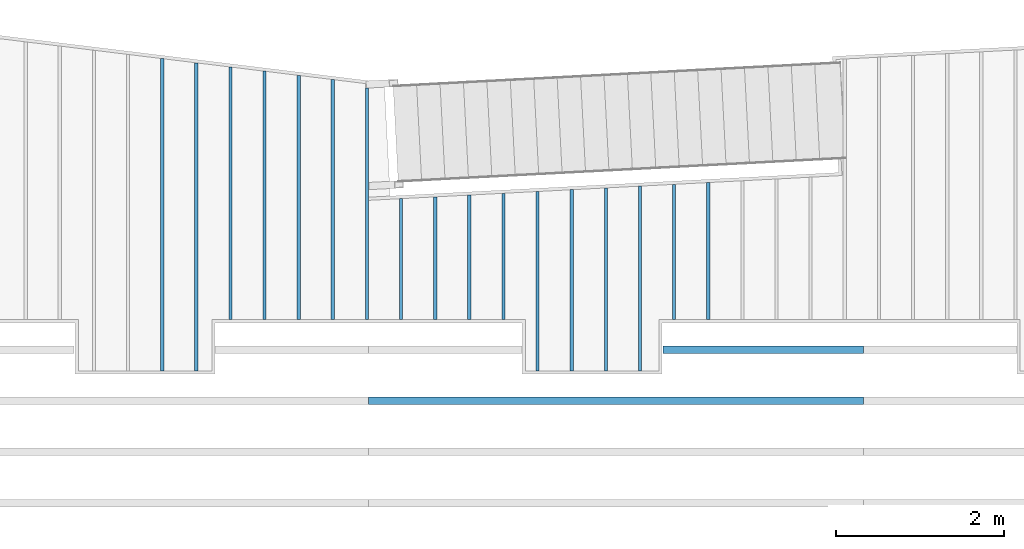
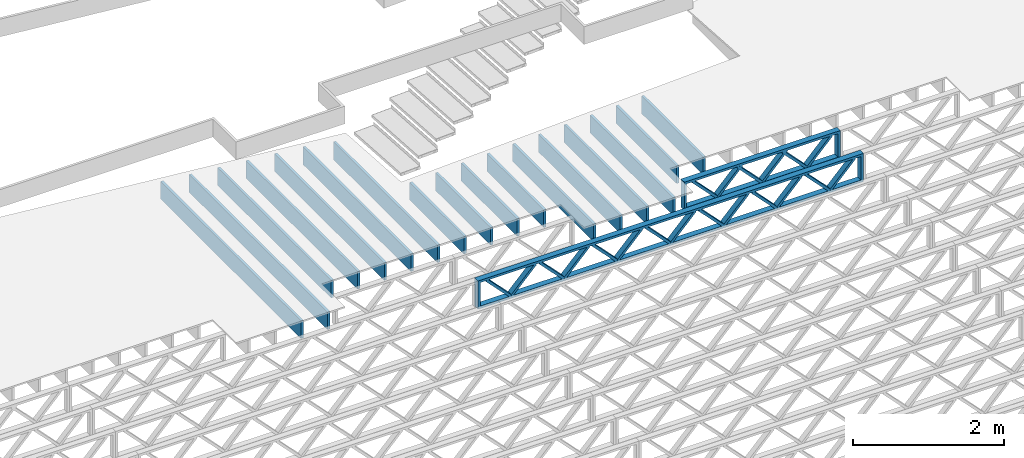
# One storey, part 10 of 23: 19 beams, 2 elements without a shape of their own.
"""IFC4 building model written with IfcOpenShell, lengths in feet."""

from ifc_helpers import new_model, entity, si_unit, converted_unit, derived_unit, direction, frame, frame_2d, origin, origin_2d_with_axis, place, context, subcontext, project, spatial, rectangle, extrude, source, transform, mapped, material, material_profile, profile_set, profile_usage, type_object, type_shapes, element, aggregate, save


model = new_model("IFC4")

# Units and contexts
model_context_1 = context("Model", 3, precision=0.0001, world=origin(), true_north=direction((6.12303176911189e-17, 1.0)))
model_context_2 = context("Model", 3, precision=0.0001, world=origin(), true_north=direction((6.12303176911189e-17, 1.0)))
body_context = subcontext(model_context_2, "Body", "Model", "MODEL_VIEW")
ifc_project = project(units=[converted_unit("LENGTHUNIT", "FOOT", entity("IfcRatioMeasure", 0.3048), si_unit("LENGTHUNIT", "METRE"), dimensions=[1, 0, 0, 0, 0, 0, 0]), converted_unit("AREAUNIT", "SQUARE FOOT", entity("IfcRatioMeasure", 0.09290304), si_unit("AREAUNIT", "SQUARE_METRE"), dimensions=[2, 0, 0, 0, 0, 0, 0]), converted_unit("VOLUMEUNIT", "CUBIC FOOT", entity("IfcRatioMeasure", 0.028316846592), si_unit("VOLUMEUNIT", "CUBIC_METRE"), dimensions=[3, 0, 0, 0, 0, 0, 0]), converted_unit("PLANEANGLEUNIT", "DEGREE", entity("IfcRatioMeasure", 0.0174532925199433), si_unit("PLANEANGLEUNIT", "RADIAN"), dimensions=[0, 0, 0, 0, 0, 0, 0]), si_unit("MASSUNIT", "GRAM", prefix="KILO"), derived_unit("MASSDENSITYUNIT", [(si_unit("MASSUNIT", "GRAM", prefix="KILO"), 1), (si_unit("LENGTHUNIT", "METRE"), -3)]), derived_unit("MOMENTOFINERTIAUNIT", [(si_unit("LENGTHUNIT", "METRE"), 4)]), si_unit("TIMEUNIT", "SECOND"), si_unit("FREQUENCYUNIT", "HERTZ"), si_unit("THERMODYNAMICTEMPERATUREUNIT", "DEGREE_CELSIUS"), derived_unit("THERMALTRANSMITTANCEUNIT", [(si_unit("MASSUNIT", "GRAM", prefix="KILO"), 1), (si_unit("THERMODYNAMICTEMPERATUREUNIT", "KELVIN"), -1), (si_unit("TIMEUNIT", "SECOND"), -3)]), derived_unit("VOLUMETRICFLOWRATEUNIT", [(si_unit("LENGTHUNIT", "METRE"), 3), (si_unit("TIMEUNIT", "SECOND"), -1)]), si_unit("ELECTRICCURRENTUNIT", "AMPERE"), si_unit("ELECTRICVOLTAGEUNIT", "VOLT"), si_unit("POWERUNIT", "WATT"), si_unit("FORCEUNIT", "NEWTON"), si_unit("ILLUMINANCEUNIT", "LUX"), si_unit("LUMINOUSFLUXUNIT", "LUMEN"), si_unit("LUMINOUSINTENSITYUNIT", "CANDELA"), derived_unit("USERDEFINED", [(si_unit("MASSUNIT", "GRAM", prefix="KILO"), -1), (si_unit("LENGTHUNIT", "METRE"), -2), (si_unit("TIMEUNIT", "SECOND"), 3), (si_unit("LUMINOUSFLUXUNIT", "LUMEN"), 1)]), derived_unit("LINEARVELOCITYUNIT", [(si_unit("LENGTHUNIT", "METRE"), 1), (si_unit("TIMEUNIT", "SECOND"), -1)]), si_unit("PRESSUREUNIT", "PASCAL"), derived_unit("USERDEFINED", [(si_unit("LENGTHUNIT", "METRE"), -2), (si_unit("MASSUNIT", "GRAM", prefix="KILO"), 1), (si_unit("TIMEUNIT", "SECOND"), -2)]), derived_unit("LINEARFORCEUNIT", [(si_unit("MASSUNIT", "GRAM", prefix="KILO"), 1), (si_unit("LENGTHUNIT", "METRE"), 1), (si_unit("TIMEUNIT", "SECOND"), -2), (si_unit("LENGTHUNIT", "METRE"), -1)]), derived_unit("PLANARFORCEUNIT", [(si_unit("MASSUNIT", "GRAM", prefix="KILO"), 1), (si_unit("LENGTHUNIT", "METRE"), 1), (si_unit("TIMEUNIT", "SECOND"), -2), (si_unit("LENGTHUNIT", "METRE"), -2)])], contexts=[model_context_1])

# Site, building, storey
site_placement = place(None, origin())
site = spatial("IfcSite", under=ifc_project, at=site_placement, CompositionType="ELEMENT")
building_placement = place(site_placement, origin())
building = spatial("IfcBuilding", under=site, at=building_placement, CompositionType="ELEMENT")
storey_placement = place(building_placement, frame((0.0, 0.0, 10.8020833333333)))
storey = spatial("IfcBuildingStorey", under=building, at=storey_placement, Name="2ND FLOOR", CompositionType="ELEMENT", Elevation=10.8020833333333)

# Assembly, beams
assembly_1_placement = place(storey_placement, origin())
assembly_1 = element("IfcElementAssembly", 1, at=assembly_1_placement, inside=storey, Name="Structural Beam System:Structural Framing System", ObjectType="Structural Beam System:Structural Framing System", AssemblyPlace="NOTDEFINED", PredefinedType="BEAM_GRID")
ifc_material_1 = material(Category="Materials")
ifc_material_profile_1 = material_profile(ifc_material_1, rectangle(XDim=0.9375, YDim=0.125000000000011, at=origin_2d_with_axis()))
ifc_profile_set_1 = profile_set([ifc_material_profile_1])
ifc_profile_usage_1 = profile_usage(ifc_profile_set_1, cardinal=8)
beam_type_1 = type_object("IfcBeamType", PredefinedType="BEAM", material=ifc_profile_set_1)
shared_shape_1 = source(origin(), body_context, "Body", "SweptSolid", [
    extrude(rectangle(XDim=0.9375, YDim=0.125000000000011, at=origin_2d_with_axis()), frame((-2.6429404122805, 0.0, 0.0), z_axis=(1.0, 0.0, 0.0), x_axis=(0.0, 0.0, -1.0)), (0.0, 0.0, 1.0), 5.28588082456099),
])
type_shapes(beam_type_1, [shared_shape_1])
beam_1_placement = place(assembly_1_placement, frame((-171.800660485462, 961.671541385545, -0.729166666666744), z_axis=(0.0, 0.0, 1.0), x_axis=(0.0, 1.0, 0.0)))
beam_1 = element("IfcBeam", 2, at=beam_1_placement, type_object=beam_type_1, material=ifc_profile_usage_1, PredefinedType="BEAM", context=body_context, shape_type="MappedRepresentation", body=[
    mapped(shared_shape_1, transform((0.0, 0.0, 0.0), scale=1.0)),
])
ifc_profile_usage_2 = profile_usage(ifc_profile_set_1, cardinal=8)
beam_type_2 = type_object("IfcBeamType", PredefinedType="BEAM", material=ifc_profile_set_1)
shared_shape_2 = source(origin(), body_context, "Body", "SweptSolid", [
    extrude(rectangle(XDim=0.9375, YDim=0.125000000000011, at=origin_2d_with_axis()), frame((-3.60800160473184, 0.0, 0.0), z_axis=(1.0, 0.0, 0.0), x_axis=(0.0, 0.0, -1.0)), (0.0, 0.0, 1.0), 7.21600320946368),
])
type_shapes(beam_type_2, [shared_shape_2])
beam_2_placement = place(assembly_1_placement, frame((-173.133993818795, 960.63660315405, -0.729166666666744), z_axis=(0.0, 0.0, 1.0), x_axis=(0.0, 1.0, 0.0)))
beam_2 = element("IfcBeam", 3, at=beam_2_placement, type_object=beam_type_2, material=ifc_profile_usage_2, PredefinedType="BEAM", context=body_context, shape_type="MappedRepresentation", body=[
    mapped(shared_shape_2, transform((0.0, 0.0, 0.0), scale=1.0)),
])
ifc_profile_usage_3 = profile_usage(ifc_profile_set_1, cardinal=8)
beam_type_3 = type_object("IfcBeamType", PredefinedType="BEAM", material=ifc_profile_set_1)
shared_shape_3 = source(origin(), body_context, "Body", "SweptSolid", [
    extrude(rectangle(XDim=0.9375, YDim=0.125000000000011, at=origin_2d_with_axis()), frame((-3.53812456568801, 0.0, 0.0), z_axis=(1.0, 0.0, 0.0), x_axis=(0.0, 0.0, -1.0)), (0.0, 0.0, 1.0), 7.07624913137602),
])
type_shapes(beam_type_3, [shared_shape_3])
beam_3_placement = place(assembly_1_placement, frame((-175.800660485462, 960.566726115006, -0.729166666666744), z_axis=(0.0, 0.0, 1.0), x_axis=(0.0, 1.0, 0.0)))
beam_3 = element("IfcBeam", 4, at=beam_3_placement, type_object=beam_type_3, material=ifc_profile_usage_3, PredefinedType="BEAM", context=body_context, shape_type="MappedRepresentation", body=[
    mapped(shared_shape_3, transform((0.0, 0.0, 0.0), scale=1.0)),
])
ifc_profile_usage_4 = profile_usage(ifc_profile_set_1, cardinal=8)
beam_type_4 = type_object("IfcBeamType", PredefinedType="BEAM", material=ifc_profile_set_1)
shared_shape_4 = source(origin(), body_context, "Body", "SweptSolid", [
    extrude(rectangle(XDim=0.9375, YDim=0.125000000000011, at=origin_2d_with_axis()), frame((-4.63214954776987, 0.0, 0.0), z_axis=(1.0, 0.0, 0.0), x_axis=(0.0, 0.0, -1.0)), (0.0, 0.0, 1.0), 9.0453350583723),
])
type_shapes(beam_type_4, [shared_shape_4])
beam_4_placement = place(assembly_1_placement, frame((-183.800660485462, 963.660753064632, -0.729166666666744), z_axis=(0.0, 0.0, 1.0), x_axis=(0.0, 1.0, 0.0)))
beam_4 = element("IfcBeam", 5, at=beam_4_placement, type_object=beam_type_4, material=ifc_profile_usage_4, PredefinedType="BEAM", context=body_context, shape_type="MappedRepresentation", body=[
    mapped(shared_shape_4, transform((0.0, 0.0, 0.0), scale=1.0)),
])
ifc_profile_usage_5 = profile_usage(ifc_profile_set_1, cardinal=8)
beam_type_5 = type_object("IfcBeamType", PredefinedType="BEAM", material=ifc_profile_set_1)
shared_shape_5 = source(origin(), body_context, "Body", "SweptSolid", [
    extrude(rectangle(XDim=0.9375, YDim=0.125000000000011, at=origin_2d_with_axis()), frame((-4.68938955176543, 0.0, 0.0), z_axis=(1.0, 0.0, 0.0), x_axis=(0.0, 0.0, -1.0)), (0.0, 0.0, 1.0), 9.37877910353086),
])
type_shapes(beam_type_5, [shared_shape_5])
beam_5_placement = place(assembly_1_placement, frame((-185.133993818795, 963.717993385622, -0.729166666666744), z_axis=(0.0, 0.0, 1.0), x_axis=(0.0, 1.0, 0.0)))
beam_5 = element("IfcBeam", 6, at=beam_5_placement, type_object=beam_type_5, material=ifc_profile_usage_5, PredefinedType="BEAM", context=body_context, shape_type="MappedRepresentation", body=[
    mapped(shared_shape_5, transform((0.0, 0.0, 0.0), scale=1.0)),
])
ifc_profile_usage_6 = profile_usage(ifc_profile_set_1, cardinal=8)
beam_type_6 = type_object("IfcBeamType", PredefinedType="BEAM", material=ifc_profile_set_1)
shared_shape_6 = source(origin(), body_context, "Body", "SweptSolid", [
    extrude(rectangle(XDim=0.9375, YDim=0.125000000000011, at=origin_2d_with_axis()), frame((-4.77124576720365, 0.0, 0.0), z_axis=(1.0, 0.0, 0.0), x_axis=(0.0, 0.0, -1.0)), (0.0, 0.0, 1.0), 9.5424915344073),
])
type_shapes(beam_type_6, [shared_shape_6])
beam_6_placement = place(assembly_1_placement, frame((-186.467327152129, 963.799849918054, -0.729166666666744), z_axis=(0.0, 0.0, 1.0), x_axis=(0.0, 1.0, 0.0)))
beam_6 = element("IfcBeam", 7, at=beam_6_placement, type_object=beam_type_6, material=ifc_profile_usage_6, PredefinedType="BEAM", context=body_context, shape_type="MappedRepresentation", body=[
    mapped(shared_shape_6, transform((0.0, 0.0, 0.0), scale=1.0)),
])

assembly_2_placement = place(storey_placement, origin())
assembly_2 = element("IfcElementAssembly", 8, at=assembly_2_placement, inside=storey, Name="Structural Beam System:Structural Framing System", ObjectType="Structural Beam System:Structural Framing System", AssemblyPlace="NOTDEFINED", PredefinedType="BEAM_GRID")
ifc_material_2 = material(Name="WOOD TRUSS", Category="Materials")
ifc_material_profile_2 = material_profile(ifc_material_2, rectangle(XDim=1.73473973950632, YDim=0.125, at=frame_2d((-1.11022302462516e-16, 8.32667268468867e-17), x_axis=(1.0, 0.0))))
ifc_material_profile_3 = material_profile(ifc_material_2, rectangle(XDim=1.73473973950633, YDim=0.125, at=frame_2d((-1.11022302462516e-16, 8.32667268468867e-17), x_axis=(1.0, 0.0))))
ifc_material_profile_4 = material_profile(ifc_material_2, rectangle(XDim=1.73473973950632, YDim=0.125, at=frame_2d((-5.55111512312578e-17, 1.38777878078145e-16), x_axis=(1.0, 0.0))))
ifc_material_profile_5 = material_profile(ifc_material_2, rectangle(XDim=1.73473973950633, YDim=0.125, at=frame_2d((-1.11022302462516e-16, 8.32667268468867e-17), x_axis=(1.0, 0.0))))
ifc_material_profile_6 = material_profile(ifc_material_2, rectangle(XDim=1.73473973950632, YDim=0.125, at=frame_2d((-1.11022302462516e-16, 8.32667268468867e-17), x_axis=(1.0, 0.0))))
ifc_material_profile_7 = material_profile(ifc_material_2, rectangle(XDim=1.73473973950633, YDim=0.125, at=frame_2d((-2.77555756156289e-16, 3.05311331771918e-16), x_axis=(1.0, 0.0))))
ifc_material_profile_8 = material_profile(ifc_material_2, rectangle(XDim=1.73473973950632, YDim=0.124999999999999, at=frame_2d((-3.88578058618805e-16, -2.4980018054066e-16), x_axis=(1.0, 0.0))))
ifc_material_profile_9 = material_profile(ifc_material_2, rectangle(XDim=1.73473973950633, YDim=0.125, at=frame_2d((2.77555756156289e-16, -3.05311331771918e-16), x_axis=(1.0, 0.0))))
ifc_material_profile_10 = material_profile(ifc_material_2, rectangle(XDim=1.73473973950632, YDim=0.124999999999999, at=frame_2d((-1.11022302462516e-16, 8.32667268468867e-17), x_axis=(1.0, 0.0))))
ifc_material_profile_11 = material_profile(ifc_material_2, rectangle(XDim=1.73473973950633, YDim=0.125, at=origin_2d_with_axis()))
ifc_material_profile_12 = material_profile(ifc_material_2, rectangle(XDim=0.124999999999982, YDim=0.291666666666668, at=origin_2d_with_axis()))
ifc_material_profile_13 = material_profile(ifc_material_2, rectangle(XDim=0.124999999999932, YDim=0.291666666666664, at=origin_2d_with_axis()))
ifc_material_profile_14 = material_profile(ifc_material_2, rectangle(XDim=1.25000000000002, YDim=0.29166666666667, at=origin_2d_with_axis()))
ifc_material_profile_15 = material_profile(ifc_material_2, rectangle(XDim=1.25000000000004, YDim=0.291666666666667, at=origin_2d_with_axis()))
ifc_profile_set_2 = profile_set([ifc_material_profile_2, ifc_material_profile_3, ifc_material_profile_4, ifc_material_profile_5, ifc_material_profile_6, ifc_material_profile_7, ifc_material_profile_8, ifc_material_profile_9, ifc_material_profile_10, ifc_material_profile_11, ifc_material_profile_12, ifc_material_profile_13, ifc_material_profile_14, ifc_material_profile_15])
ifc_profile_usage_7 = profile_usage(ifc_profile_set_2, cardinal=8)
beam_type_7 = type_object("IfcBeamType", PredefinedType="BEAM", material=ifc_profile_set_2)
shared_shape_7 = source(origin(), body_context, "Body", "SweptSolid", [
    extrude(rectangle(XDim=1.73473973950632, YDim=0.124999999999999, at=frame_2d((5.55111512312578e-16, 7.21644966006352e-16), x_axis=(1.0, 0.0))), frame((5.95847627016997, -0.145833333333334, 0.0), z_axis=(0.0, 1.0, 0.0), x_axis=(0.693383046997606, 0.0, 0.720569184836762)), (0.0, 0.0, 1.0), 0.291666666666667),
    extrude(rectangle(XDim=1.73473973950633, YDim=0.125, at=origin_2d_with_axis()), frame((4.7081903964967, -0.145833333333334, 0.0), z_axis=(0.0, 1.0, 0.0), x_axis=(0.69338304699761, 0.0, -0.720569184836758)), (0.0, 0.0, 1.0), 0.291666666666666),
    extrude(rectangle(XDim=1.73473973950632, YDim=0.125, at=frame_2d((2.22044604925031e-16, 3.88578058618805e-16), x_axis=(1.0, 0.0))), frame((3.29180960350347, -0.145833333333334, 0.0), z_axis=(0.0, 1.0, 0.0), x_axis=(0.693383046997606, 0.0, 0.720569184836762)), (0.0, 0.0, 1.0), 0.291666666666667),
    extrude(rectangle(XDim=1.73473973950633, YDim=0.125, at=frame_2d((1.11022302462516e-16, -8.32667268468867e-17), x_axis=(1.0, 0.0))), frame((2.0415237298302, -0.145833333333334, 0.0), z_axis=(0.0, 1.0, 0.0), x_axis=(0.69338304699761, 0.0, -0.720569184836758)), (0.0, 0.0, 1.0), 0.291666666666667),
    extrude(rectangle(XDim=1.73473973950632, YDim=0.125, at=frame_2d((-5.55111512312578e-17, 1.38777878078145e-16), x_axis=(1.0, 0.0))), frame((0.625142936836964, -0.145833333333334, 0.0), z_axis=(0.0, 1.0, 0.0), x_axis=(0.693383046997606, 0.0, 0.720569184836762)), (0.0, 0.0, 1.0), 0.291666666666667),
    extrude(rectangle(XDim=1.73473973950633, YDim=0.125, at=frame_2d((-1.11022302462516e-16, 8.32667268468867e-17), x_axis=(1.0, 0.0))), frame((-0.625142936836306, -0.145833333333334, 0.0), z_axis=(0.0, 1.0, 0.0), x_axis=(0.69338304699761, 0.0, -0.720569184836758)), (0.0, 0.0, 1.0), 0.291666666666667),
    extrude(rectangle(XDim=1.73473973950632, YDim=0.125, at=frame_2d((-1.11022302462516e-16, 8.32667268468867e-17), x_axis=(1.0, 0.0))), frame((-2.04152372982954, -0.145833333333334, 0.0), z_axis=(0.0, 1.0, 0.0), x_axis=(0.693383046997606, 0.0, 0.720569184836762)), (0.0, 0.0, 1.0), 0.291666666666667),
    extrude(rectangle(XDim=1.73473973950633, YDim=0.125, at=origin_2d_with_axis()), frame((-3.29180960350281, -0.145833333333334, 0.0), z_axis=(0.0, 1.0, 0.0), x_axis=(0.69338304699761, 0.0, -0.720569184836758)), (0.0, 0.0, 1.0), 0.291666666666667),
    extrude(rectangle(XDim=1.73473973950632, YDim=0.124999999999999, at=frame_2d((-1.11022302462516e-16, 8.32667268468867e-17), x_axis=(1.0, 0.0))), frame((-4.70819039649604, -0.145833333333334, 0.0), z_axis=(0.0, 1.0, 0.0), x_axis=(0.693383046997606, 0.0, 0.720569184836762)), (0.0, 0.0, 1.0), 0.291666666666667),
    extrude(rectangle(XDim=1.73473973950633, YDim=0.125, at=frame_2d((-5.55111512312578e-16, 6.38378239159465e-16), x_axis=(1.0, 0.0))), frame((-5.95847627016931, -0.145833333333334, 0.0), z_axis=(0.0, 1.0, 0.0), x_axis=(0.69338304699761, 0.0, -0.720569184836758)), (0.0, 0.0, 1.0), 0.291666666666666),
    extrude(rectangle(XDim=1.73473973950632, YDim=0.125, at=frame_2d((-7.21644966006352e-16, -5.82867087928207e-16), x_axis=(1.0, 0.0))), frame((8.62514293683647, -0.145833333333334, 0.0), z_axis=(0.0, 1.0, 0.0), x_axis=(0.693383046997607, 0.0, 0.720569184836761)), (0.0, 0.0, 1.0), 0.291666666666667),
    extrude(rectangle(XDim=1.73473973950633, YDim=0.125, at=origin_2d_with_axis()), frame((7.3748570631632, -0.145833333333334, 0.0), z_axis=(0.0, 1.0, 0.0), x_axis=(0.69338304699761, 0.0, -0.720569184836758)), (0.0, 0.0, 1.0), 0.291666666666666),
    extrude(rectangle(XDim=1.73473973950632, YDim=0.124999999999999, at=frame_2d((-1.11022302462516e-16, 8.32667268468867e-17), x_axis=(1.0, 0.0))), frame((-7.37485706316255, -0.145833333333334, 0.0), z_axis=(0.0, 1.0, 0.0), x_axis=(0.693383046997606, 0.0, 0.720569184836762)), (0.0, 0.0, 1.0), 0.291666666666667),
    extrude(rectangle(XDim=1.73473973950633, YDim=0.125, at=origin_2d_with_axis()), frame((-8.62514293683582, -0.145833333333334, 0.0), z_axis=(0.0, 1.0, 0.0), x_axis=(0.69338304699761, 0.0, -0.720569184836758)), (0.0, 0.0, 1.0), 0.291666666666666),
    extrude(rectangle(XDim=0.124999999999982, YDim=0.291666666666668, at=origin_2d_with_axis()), frame((-9.66666666666609, 0.0, 0.687500000000054), z_axis=(1.0, 0.0, 0.0), x_axis=(0.0, 0.0, -1.0)), (0.0, 0.0, 1.0), 19.3333333333322),
    extrude(rectangle(XDim=0.124999999999932, YDim=0.291666666666664, at=origin_2d_with_axis()), frame((-9.66666666666588, 0.0, -0.687499999999984), z_axis=(1.0, 0.0, 0.0), x_axis=(0.0, 0.0, -1.0)), (0.0, 0.0, 1.0), 19.333333333332),
    extrude(rectangle(XDim=1.25000000000002, YDim=0.29166666666667, at=origin_2d_with_axis()), frame((9.54166666666607, 0.0, 0.0), z_axis=(1.0, 0.0, 0.0), x_axis=(0.0, 0.0, -1.0)), (0.0, 0.0, 1.0), 0.12500000000002),
    extrude(rectangle(XDim=1.25000000000004, YDim=0.291666666666667, at=origin_2d_with_axis()), frame((-9.66666666666609, 0.0, 0.0), z_axis=(1.0, 0.0, 0.0), x_axis=(0.0, 0.0, -1.0)), (0.0, 0.0, 1.0), 0.125000000000023),
])
type_shapes(beam_type_7, [shared_shape_7])
beam_7_placement = place(assembly_2_placement, frame((-174.071493818896, 955.861934882651, -0.947916666666657), z_axis=(0.0, 0.0, 1.0), x_axis=(-1.0, 0.0, 0.0)))
beam_7 = element("IfcBeam", 9, at=beam_7_placement, type_object=beam_type_7, material=ifc_profile_usage_7, PredefinedType="BEAM", context=body_context, shape_type="MappedRepresentation", body=[
    mapped(shared_shape_7, transform((0.0, 0.0, 0.0), scale=1.0)),
])
ifc_profile_usage_8 = profile_usage(ifc_profile_set_2, cardinal=8)
beam_type_8 = type_object("IfcBeamType", PredefinedType="BEAM", material=ifc_profile_set_2)
shared_shape_8 = source(origin(), body_context, "Body", "SweptSolid", [
    extrude(rectangle(XDim=1.73473973950632, YDim=0.125, at=frame_2d((-5.55111512312578e-17, 1.38777878078145e-16), x_axis=(1.0, 0.0))), frame((0.625142936836962, -0.145833333333334, 0.0), z_axis=(0.0, 1.0, 0.0), x_axis=(0.693383046997606, 0.0, 0.720569184836762)), (0.0, 0.0, 1.0), 0.291666666666667),
    extrude(rectangle(XDim=1.73473973950633, YDim=0.125, at=frame_2d((-1.11022302462516e-16, 8.32667268468867e-17), x_axis=(1.0, 0.0))), frame((-0.625142936836309, -0.145833333333334, 0.0), z_axis=(0.0, 1.0, 0.0), x_axis=(0.69338304699761, 0.0, -0.720569184836758)), (0.0, 0.0, 1.0), 0.291666666666667),
    extrude(rectangle(XDim=1.73473973950632, YDim=0.125, at=frame_2d((-1.11022302462516e-16, 8.32667268468867e-17), x_axis=(1.0, 0.0))), frame((2.87514283803796, -0.145833333333334, 0.0), z_axis=(0.0, 1.0, 0.0), x_axis=(0.693383046997606, 0.0, 0.720569184836762)), (0.0, 0.0, 1.0), 0.291666666666667),
    extrude(rectangle(XDim=1.73473973950633, YDim=0.125, at=frame_2d((-1.11022302462516e-16, 8.32667268468867e-17), x_axis=(1.0, 0.0))), frame((1.62485696436469, -0.145833333333334, 0.0), z_axis=(0.0, 1.0, 0.0), x_axis=(0.69338304699761, 0.0, -0.720569184836758)), (0.0, 0.0, 1.0), 0.291666666666667),
    extrude(rectangle(XDim=1.73473973950632, YDim=0.125, at=frame_2d((-1.11022302462516e-16, 8.32667268468867e-17), x_axis=(1.0, 0.0))), frame((-1.62485696436403, -0.145833333333334, 0.0), z_axis=(0.0, 1.0, 0.0), x_axis=(0.693383046997606, 0.0, 0.720569184836762)), (0.0, 0.0, 1.0), 0.291666666666667),
    extrude(rectangle(XDim=1.73473973950633, YDim=0.125, at=origin_2d_with_axis()), frame((-2.87514283803731, -0.145833333333334, 0.0), z_axis=(0.0, 1.0, 0.0), x_axis=(0.69338304699761, 0.0, -0.720569184836758)), (0.0, 0.0, 1.0), 0.291666666666667),
    extrude(rectangle(XDim=0.124999999999982, YDim=0.291666666666668, at=origin_2d_with_axis()), frame((-3.91666656786758, 0.0, 0.687500000000054), z_axis=(1.0, 0.0, 0.0), x_axis=(0.0, 0.0, -1.0)), (0.0, 0.0, 1.0), 7.83333313573516),
    extrude(rectangle(XDim=0.124999999999932, YDim=0.291666666666664, at=origin_2d_with_axis()), frame((-3.91666656786737, 0.0, -0.687499999999984), z_axis=(1.0, 0.0, 0.0), x_axis=(0.0, 0.0, -1.0)), (0.0, 0.0, 1.0), 7.83333313573495),
    extrude(rectangle(XDim=1.25000000000002, YDim=0.29166666666667, at=origin_2d_with_axis()), frame((3.79166656786756, 0.0, 0.0), z_axis=(1.0, 0.0, 0.0), x_axis=(0.0, 0.0, -1.0)), (0.0, 0.0, 1.0), 0.12500000000002),
    extrude(rectangle(XDim=1.25000000000004, YDim=0.291666666666667, at=origin_2d_with_axis()), frame((-3.91666656786758, 0.0, 0.0), z_axis=(1.0, 0.0, 0.0), x_axis=(0.0, 0.0, -1.0)), (0.0, 0.0, 1.0), 0.125000000000023),
])
type_shapes(beam_type_8, [shared_shape_8])
beam_8_placement = place(assembly_2_placement, frame((-168.321493720097, 957.861934882651, -0.947916666666657), z_axis=(0.0, 0.0, 1.0), x_axis=(-1.0, 0.0, 0.0)))
beam_8 = element("IfcBeam", 10, at=beam_8_placement, type_object=beam_type_8, material=ifc_profile_usage_8, PredefinedType="BEAM", context=body_context, shape_type="MappedRepresentation", body=[
    mapped(shared_shape_8, transform((0.0, 0.0, 0.0), scale=1.0)),
])
aggregate(assembly_2, [beam_7, beam_8])

# Beam
ifc_profile_usage_9 = profile_usage(ifc_profile_set_1, cardinal=8)
beam_type_9 = type_object("IfcBeamType", PredefinedType="BEAM", material=ifc_profile_set_1)
shared_shape_9 = source(origin(), body_context, "Body", "SweptSolid", [
    extrude(rectangle(XDim=0.9375, YDim=0.125000000000011, at=origin_2d_with_axis()), frame((-2.43330849884109, 0.0, 0.0), z_axis=(1.0, 0.0, 0.0), x_axis=(0.0, 0.0, -1.0)), (0.0, 0.0, 1.0), 4.86661699768217),
])
type_shapes(beam_type_9, [shared_shape_9])
beam_9_placement = place(assembly_1_placement, frame((-179.800660485462, 961.461911064721, -0.729166666666744), z_axis=(0.0, 0.0, 1.0), x_axis=(0.0, 1.0, 0.0)))
beam_9 = element("IfcBeam", 11, at=beam_9_placement, type_object=beam_type_9, material=ifc_profile_usage_9, PredefinedType="BEAM", context=body_context, shape_type="MappedRepresentation", body=[
    mapped(shared_shape_9, transform((0.0, 0.0, 0.0), scale=1.0)),
])

ifc_profile_usage_10 = profile_usage(ifc_profile_set_1, cardinal=8)
beam_type_10 = type_object("IfcBeamType", PredefinedType="BEAM", material=ifc_profile_set_1)
shared_shape_10 = source(origin(), body_context, "Body", "SweptSolid", [
    extrude(rectangle(XDim=0.9375, YDim=0.125000000000011, at=origin_2d_with_axis()), frame((-2.39836982082215, 0.0, 0.0), z_axis=(1.0, 0.0, 0.0), x_axis=(0.0, 0.0, -1.0)), (0.0, 0.0, 1.0), 4.79673964164431),
])
type_shapes(beam_type_10, [shared_shape_10])
beam_10_placement = place(assembly_1_placement, frame((-181.133993818795, 961.426972703696, -0.729166666666744), z_axis=(0.0, 0.0, 1.0), x_axis=(0.0, 1.0, 0.0)))
beam_10 = element("IfcBeam", 12, at=beam_10_placement, type_object=beam_type_10, material=ifc_profile_usage_10, PredefinedType="BEAM", context=body_context, shape_type="MappedRepresentation", body=[
    mapped(shared_shape_10, transform((0.0, 0.0, 0.0), scale=1.0)),
])

ifc_profile_usage_11 = profile_usage(ifc_profile_set_1, cardinal=8)
beam_type_11 = type_object("IfcBeamType", PredefinedType="BEAM", material=ifc_profile_set_1)
shared_shape_11 = source(origin(), body_context, "Body", "SweptSolid", [
    extrude(rectangle(XDim=0.9375, YDim=0.125000000000011, at=origin_2d_with_axis()), frame((-6.01681618977585, 0.0, 0.0), z_axis=(1.0, 0.0, 0.0), x_axis=(0.0, 0.0, -1.0)), (0.0, 0.0, 1.0), 12.0336323795517),
])
type_shapes(beam_type_11, [shared_shape_11])
beam_11_placement = place(assembly_1_placement, frame((-190.467327152129, 963.045417739093, -0.729166666666744), z_axis=(0.0, 0.0, 1.0), x_axis=(0.0, 1.0, 0.0)))
beam_11 = element("IfcBeam", 13, at=beam_11_placement, type_object=beam_type_11, material=ifc_profile_usage_11, PredefinedType="BEAM", context=body_context, shape_type="MappedRepresentation", body=[
    mapped(shared_shape_11, transform((0.0, 0.0, 0.0), scale=1.0)),
])

ifc_profile_usage_12 = profile_usage(ifc_profile_set_1, cardinal=8)
beam_type_12 = type_object("IfcBeamType", PredefinedType="BEAM", material=ifc_profile_set_1)
shared_shape_12 = source(origin(), body_context, "Body", "SweptSolid", [
    extrude(rectangle(XDim=0.9375, YDim=0.125000000000011, at=origin_2d_with_axis()), frame((-6.09867256371109, 0.0, 0.0), z_axis=(1.0, 0.0, 0.0), x_axis=(0.0, 0.0, -1.0)), (0.0, 0.0, 1.0), 12.1973451274222),
])
type_shapes(beam_type_12, [shared_shape_12])
beam_12_placement = place(assembly_1_placement, frame((-191.800660485462, 963.127274113029, -0.729166666666744), z_axis=(0.0, 0.0, 1.0), x_axis=(0.0, 1.0, 0.0)))
beam_12 = element("IfcBeam", 14, at=beam_12_placement, type_object=beam_type_12, material=ifc_profile_usage_12, PredefinedType="BEAM", context=body_context, shape_type="MappedRepresentation", body=[
    mapped(shared_shape_12, transform((0.0, 0.0, 0.0), scale=1.0)),
])

ifc_profile_usage_13 = profile_usage(ifc_profile_set_1, cardinal=8)
beam_type_13 = type_object("IfcBeamType", PredefinedType="BEAM", material=ifc_profile_set_1)
shared_shape_13 = source(origin(), body_context, "Body", "SweptSolid", [
    extrude(rectangle(XDim=0.9375, YDim=0.125000000000011, at=origin_2d_with_axis()), frame((-4.93495819808015, 0.0, 0.0), z_axis=(1.0, 0.0, 0.0), x_axis=(0.0, 0.0, -1.0)), (0.0, 0.0, 1.0), 9.86991639616031),
])
type_shapes(beam_type_13, [shared_shape_13])
beam_13_placement = place(assembly_1_placement, frame((-189.133993818795, 963.963562982918, -0.729166666666744), z_axis=(0.0, 0.0, 1.0), x_axis=(0.0, 1.0, 0.0)))
beam_13 = element("IfcBeam", 15, at=beam_13_placement, type_object=beam_type_13, material=ifc_profile_usage_13, PredefinedType="BEAM", context=body_context, shape_type="MappedRepresentation", body=[
    mapped(shared_shape_13, transform((0.0, 0.0, 0.0), scale=1.0)),
])

ifc_profile_usage_14 = profile_usage(ifc_profile_set_1, cardinal=8)
beam_type_14 = type_object("IfcBeamType", PredefinedType="BEAM", material=ifc_profile_set_1)
shared_shape_14 = source(origin(), body_context, "Body", "SweptSolid", [
    extrude(rectangle(XDim=0.9375, YDim=0.125000000000011, at=origin_2d_with_axis()), frame((-4.85310198264193, 0.0, 0.0), z_axis=(1.0, 0.0, 0.0), x_axis=(0.0, 0.0, -1.0)), (0.0, 0.0, 1.0), 9.70620396528386),
])
type_shapes(beam_type_14, [shared_shape_14])
beam_14_placement = place(assembly_1_placement, frame((-187.800660485462, 963.881706450486, -0.729166666666744), z_axis=(0.0, 0.0, 1.0), x_axis=(0.0, 1.0, 0.0)))
beam_14 = element("IfcBeam", 16, at=beam_14_placement, type_object=beam_type_14, material=ifc_profile_usage_14, PredefinedType="BEAM", context=body_context, shape_type="MappedRepresentation", body=[
    mapped(shared_shape_14, transform((0.0, 0.0, 0.0), scale=1.0)),
])

ifc_profile_usage_15 = profile_usage(ifc_profile_set_1, cardinal=8)
beam_type_15 = type_object("IfcBeamType", PredefinedType="BEAM", material=ifc_profile_set_1)
shared_shape_15 = source(origin(), body_context, "Body", "SweptSolid", [
    extrude(rectangle(XDim=0.9375, YDim=0.125000000000011, at=origin_2d_with_axis()), frame((-2.36343114280317, 0.0, 0.0), z_axis=(1.0, 0.0, 0.0), x_axis=(0.0, 0.0, -1.0)), (0.0, 0.0, 1.0), 4.72686228560633),
])
type_shapes(beam_type_15, [shared_shape_15])
beam_15_placement = place(assembly_1_placement, frame((-182.467327152129, 961.392034342671, -0.729166666666744), z_axis=(0.0, 0.0, 1.0), x_axis=(0.0, 1.0, 0.0)))
beam_15 = element("IfcBeam", 17, at=beam_15_placement, type_object=beam_type_15, material=ifc_profile_usage_15, PredefinedType="BEAM", context=body_context, shape_type="MappedRepresentation", body=[
    mapped(shared_shape_15, transform((0.0, 0.0, 0.0), scale=1.0)),
])

ifc_profile_usage_16 = profile_usage(ifc_profile_set_1, cardinal=8)
beam_type_16 = type_object("IfcBeamType", PredefinedType="BEAM", material=ifc_profile_set_1)
shared_shape_16 = source(origin(), body_context, "Body", "SweptSolid", [
    extrude(rectangle(XDim=0.9375, YDim=0.125000000000011, at=origin_2d_with_axis()), frame((-2.46824717686007, 0.0, 0.0), z_axis=(1.0, 0.0, 0.0), x_axis=(0.0, 0.0, -1.0)), (0.0, 0.0, 1.0), 4.93649435372015),
])
type_shapes(beam_type_16, [shared_shape_16])
beam_16_placement = place(assembly_1_placement, frame((-178.467327152129, 961.496849425746, -0.729166666666744), z_axis=(0.0, 0.0, 1.0), x_axis=(0.0, 1.0, 0.0)))
beam_16 = element("IfcBeam", 18, at=beam_16_placement, type_object=beam_type_16, material=ifc_profile_usage_16, PredefinedType="BEAM", context=body_context, shape_type="MappedRepresentation", body=[
    mapped(shared_shape_16, transform((0.0, 0.0, 0.0), scale=1.0)),
])

ifc_profile_usage_17 = profile_usage(ifc_profile_set_1, cardinal=8)
beam_type_17 = type_object("IfcBeamType", PredefinedType="BEAM", material=ifc_profile_set_1)
shared_shape_17 = source(origin(), body_context, "Body", "SweptSolid", [
    extrude(rectangle(XDim=0.9375, YDim=0.125000000000011, at=origin_2d_with_axis()), frame((-3.50318604616604, 0.0, 0.0), z_axis=(1.0, 0.0, 0.0), x_axis=(0.0, 0.0, -1.0)), (0.0, 0.0, 1.0), 7.00637209233207),
])
type_shapes(beam_type_17, [shared_shape_17])
beam_17_placement = place(assembly_1_placement, frame((-177.133993818795, 960.531787595484, -0.729166666666744), z_axis=(0.0, 0.0, 1.0), x_axis=(0.0, 1.0, 0.0)))
beam_17 = element("IfcBeam", 19, at=beam_17_placement, type_object=beam_type_17, material=ifc_profile_usage_17, PredefinedType="BEAM", context=body_context, shape_type="MappedRepresentation", body=[
    mapped(shared_shape_17, transform((0.0, 0.0, 0.0), scale=1.0)),
])

ifc_profile_usage_18 = profile_usage(ifc_profile_set_1, cardinal=8)
beam_type_18 = type_object("IfcBeamType", PredefinedType="BEAM", material=ifc_profile_set_1)
shared_shape_18 = source(origin(), body_context, "Body", "SweptSolid", [
    extrude(rectangle(XDim=0.9375, YDim=0.125000000000011, at=origin_2d_with_axis()), frame((-3.57306308520992, 0.0, 0.0), z_axis=(1.0, 0.0, 0.0), x_axis=(0.0, 0.0, -1.0)), (0.0, 0.0, 1.0), 7.14612617041985),
])
type_shapes(beam_type_18, [shared_shape_18])
beam_18_placement = place(assembly_1_placement, frame((-174.467327152129, 960.601664634528, -0.729166666666744), z_axis=(0.0, 0.0, 1.0), x_axis=(0.0, 1.0, 0.0)))
beam_18 = element("IfcBeam", 20, at=beam_18_placement, type_object=beam_type_18, material=ifc_profile_usage_18, PredefinedType="BEAM", context=body_context, shape_type="MappedRepresentation", body=[
    mapped(shared_shape_18, transform((0.0, 0.0, 0.0), scale=1.0)),
])

ifc_profile_usage_19 = profile_usage(ifc_profile_set_1, cardinal=8)
beam_type_19 = type_object("IfcBeamType", PredefinedType="BEAM", material=ifc_profile_set_1)
shared_shape_19 = source(origin(), body_context, "Body", "SweptSolid", [
    extrude(rectangle(XDim=0.9375, YDim=0.125000000000011, at=origin_2d_with_axis()), frame((-2.67787876430128, 0.0, 0.0), z_axis=(1.0, 0.0, 0.0), x_axis=(0.0, 0.0, -1.0)), (0.0, 0.0, 1.0), 5.35575752860257),
])
type_shapes(beam_type_19, [shared_shape_19])
beam_19_placement = place(assembly_1_placement, frame((-170.467327152129, 961.706480072568, -0.729166666666744), z_axis=(0.0, 0.0, 1.0), x_axis=(0.0, 1.0, 0.0)))
beam_19 = element("IfcBeam", 21, at=beam_19_placement, type_object=beam_type_19, material=ifc_profile_usage_19, PredefinedType="BEAM", context=body_context, shape_type="MappedRepresentation", body=[
    mapped(shared_shape_19, transform((0.0, 0.0, 0.0), scale=1.0)),
])

aggregate(assembly_1, [beam_1, beam_2, beam_3, beam_4, beam_5, beam_6, beam_9, beam_10, beam_11, beam_12, beam_13, beam_14, beam_15, beam_16, beam_17, beam_18, beam_19])

save(model, "model.ifc")
